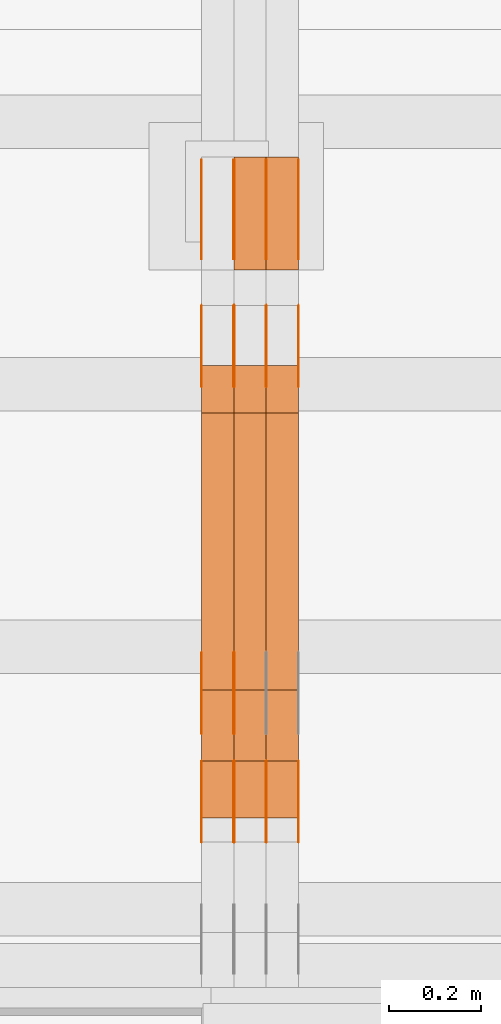
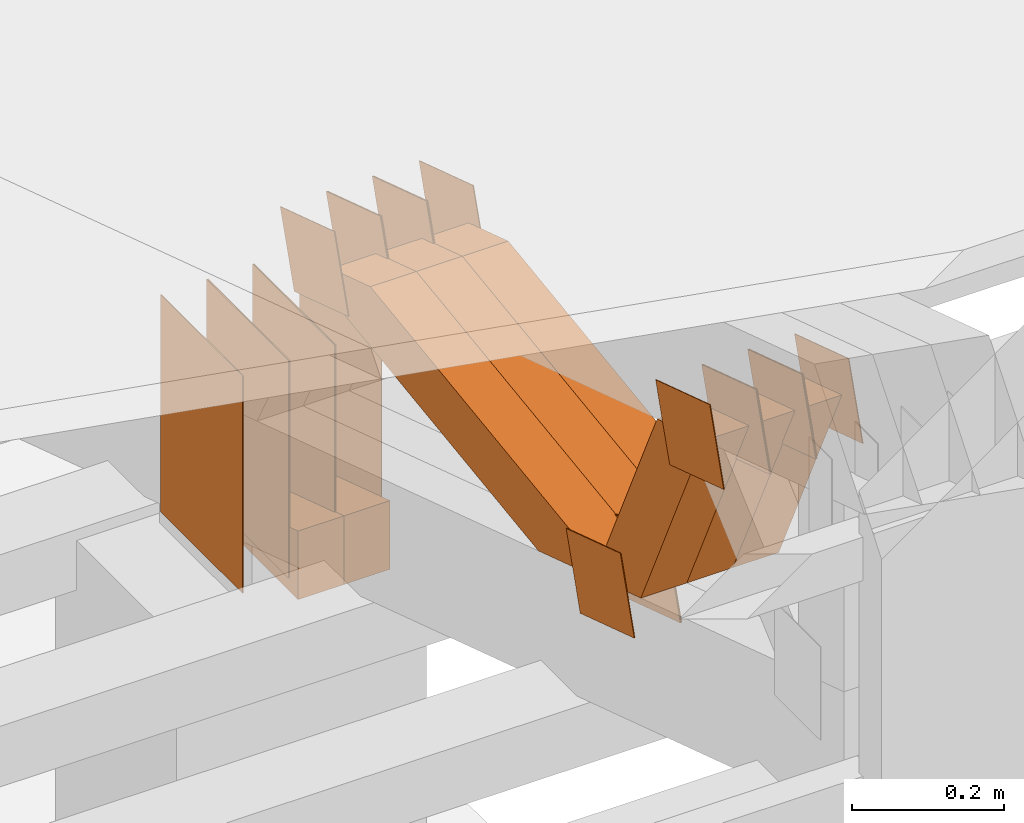
# One storey, part 303 of 385: 29 proxies.
"""IFC2X3 building model written with IfcOpenShell, lengths in millimetres."""

from ifc_helpers import new_model, entity, si_unit, converted_unit, derived_unit, direction, frame, origin, origin_2d_with_axis, place, context, subcontext, project, spatial, polyline, rectangle, outline, extrude, source, transform, mapped, material, type_object, type_shapes, element, save


model = new_model("IFC2X3")

# Units and contexts
model_context = context("Model", 3, precision=0.01, world=origin(), true_north=direction((6.12303176911189e-17, 1.0)))
body_context = subcontext(model_context, "Body", "Model", "MODEL_VIEW")
ifc_project = project(units=[si_unit("LENGTHUNIT", "METRE", prefix="MILLI"), si_unit("AREAUNIT", "SQUARE_METRE"), si_unit("VOLUMEUNIT", "CUBIC_METRE"), converted_unit("PLANEANGLEUNIT", "DEGREE", entity("IfcRatioMeasure", 0.0174532925199433), si_unit("PLANEANGLEUNIT", "RADIAN"), dimensions=[0, 0, 0, 0, 0, 0, 0]), si_unit("MASSUNIT", "GRAM", prefix="KILO"), derived_unit("MASSDENSITYUNIT", [(si_unit("MASSUNIT", "GRAM", prefix="KILO"), 1), (si_unit("LENGTHUNIT", "METRE"), -3)]), si_unit("TIMEUNIT", "SECOND"), si_unit("FREQUENCYUNIT", "HERTZ"), si_unit("THERMODYNAMICTEMPERATUREUNIT", "DEGREE_CELSIUS"), derived_unit("THERMALTRANSMITTANCEUNIT", [(si_unit("MASSUNIT", "GRAM", prefix="KILO"), 1), (si_unit("THERMODYNAMICTEMPERATUREUNIT", "KELVIN"), -1), (si_unit("TIMEUNIT", "SECOND"), -3)]), derived_unit("VOLUMETRICFLOWRATEUNIT", [(si_unit("LENGTHUNIT", "METRE"), 3), (si_unit("TIMEUNIT", "SECOND"), -1)]), si_unit("ELECTRICCURRENTUNIT", "AMPERE"), si_unit("ELECTRICVOLTAGEUNIT", "VOLT"), si_unit("POWERUNIT", "WATT"), si_unit("FORCEUNIT", "NEWTON", prefix="KILO"), si_unit("ILLUMINANCEUNIT", "LUX"), si_unit("LUMINOUSFLUXUNIT", "LUMEN"), si_unit("LUMINOUSINTENSITYUNIT", "CANDELA"), derived_unit("USERDEFINED", [(si_unit("MASSUNIT", "GRAM", prefix="KILO"), -1), (si_unit("LENGTHUNIT", "METRE"), -2), (si_unit("TIMEUNIT", "SECOND"), 3), (si_unit("LUMINOUSFLUXUNIT", "LUMEN"), 1)]), derived_unit("LINEARVELOCITYUNIT", [(si_unit("LENGTHUNIT", "METRE"), 1), (si_unit("TIMEUNIT", "SECOND"), -1)]), si_unit("PRESSUREUNIT", "PASCAL"), derived_unit("USERDEFINED", [(si_unit("LENGTHUNIT", "METRE"), -2), (si_unit("MASSUNIT", "GRAM", prefix="KILO"), 1), (si_unit("TIMEUNIT", "SECOND"), -2)])], contexts=[model_context])

# Site, building, storey
site_placement = place(None, origin())
site = spatial("IfcSite", under=ifc_project, at=site_placement, CompositionType="ELEMENT")
building_placement = place(site_placement, origin())
building = spatial("IfcBuilding", under=site, at=building_placement, CompositionType="ELEMENT")
storey_placement = place(building_placement, origin())
storey = spatial("IfcBuildingStorey", under=building, at=storey_placement, Name="Default", CompositionType="ELEMENT", Elevation=0.0)

# Proxies
ifc_material_1 = material(Name="IfcSurfaceStyle #549185")
building_element_proxy_type_1 = type_object("IfcBuildingElementProxyType", PredefinedType="NOTDEFINED", material=ifc_material_1)
shared_shape_1 = source(origin(), body_context, "Body", "SweptSolid", [
    extrude(outline(polyline([(-74.9998605591118, -59.9999264677601), (74.9998754286171, -59.9999264677601), (74.9998605591118, 59.9999264677602), (-74.9998754286171, 59.9999264677602), (-74.9998605591118, -59.9999264677601)])), frame((74.9998754286171, 60.0000503992849, 0.0), z_axis=(0.0, 0.0, 1.0), x_axis=(-1.0, 0.0, 0.0)), (0.0, 0.0, 1.0), 1.29999999999999),
])
type_shapes(building_element_proxy_type_1, [shared_shape_1])
proxy_1_placement = place(building_placement, frame((45245.0, 16352.8320303235, 3323.23212676408), z_axis=(-1.0, 0.0, 0.0), x_axis=(0.0, -0.951056516295124, 0.309016994375039)))
element("IfcBuildingElementProxy", 1, at=proxy_1_placement, inside=storey, type_object=building_element_proxy_type_1, material=ifc_material_1, context=body_context, shape_type="MappedRepresentation", body=[
    mapped(shared_shape_1, transform((0.0, 0.0, 0.0), scale=1.0)),
])
ifc_material_2 = material(Name="IfcSurfaceStyle #549128")
building_element_proxy_type_2 = type_object("IfcBuildingElementProxyType", PredefinedType="NOTDEFINED", material=ifc_material_2)
shared_shape_2 = source(origin(), body_context, "Body", "SweptSolid", [
    extrude(outline(polyline([(-74.9998605591118, -59.9999264677601), (74.9998754286171, -59.9999264677601), (74.9998605591118, 59.9999264677602), (-74.9998754286171, 59.9999264677602), (-74.9998605591118, -59.9999264677601)])), frame((74.9998754286171, 60.0000503992849, 0.0), z_axis=(0.0, 0.0, 1.0), x_axis=(-1.0, 0.0, 0.0)), (0.0, 0.0, 1.0), 1.29999999999999),
])
type_shapes(building_element_proxy_type_2, [shared_shape_2])
proxy_2_placement = place(building_placement, frame((45246.3, 16352.8320303235, 3323.23212676408), z_axis=(-1.0, 0.0, 0.0), x_axis=(0.0, -0.951056516295124, 0.309016994375039)))
element("IfcBuildingElementProxy", 2, at=proxy_2_placement, inside=storey, type_object=building_element_proxy_type_2, material=ifc_material_2, context=body_context, shape_type="MappedRepresentation", body=[
    mapped(shared_shape_2, transform((0.0, 0.0, 0.0), scale=1.0)),
])
ifc_material_3 = material(Name="IfcSurfaceStyle #549071")
building_element_proxy_type_3 = type_object("IfcBuildingElementProxyType", PredefinedType="NOTDEFINED", material=ifc_material_3)
shared_shape_3 = source(origin(), body_context, "Body", "SweptSolid", [
    extrude(outline(polyline([(-74.9998605591118, -59.9999264677601), (74.9998754286171, -59.9999264677601), (74.9998605591118, 59.9999264677602), (-74.9998754286171, 59.9999264677602), (-74.9998605591118, -59.9999264677601)])), frame((74.9998754286171, 60.0000503992849, 0.0), z_axis=(0.0, 0.0, 1.0), x_axis=(-1.0, 0.0, 0.0)), (0.0, 0.0, 1.0), 1.29999999999999),
])
type_shapes(building_element_proxy_type_3, [shared_shape_3])
proxy_3_placement = place(building_placement, frame((45175.0, 16352.8320303235, 3323.23212676408), z_axis=(-1.0, 0.0, 0.0), x_axis=(0.0, -0.951056516295124, 0.309016994375039)))
element("IfcBuildingElementProxy", 3, at=proxy_3_placement, inside=storey, type_object=building_element_proxy_type_3, material=ifc_material_3, context=body_context, shape_type="MappedRepresentation", body=[
    mapped(shared_shape_3, transform((0.0, 0.0, 0.0), scale=1.0)),
])
ifc_material_4 = material(Name="IfcSurfaceStyle #546962")
building_element_proxy_type_4 = type_object("IfcBuildingElementProxyType", PredefinedType="NOTDEFINED", material=ifc_material_4)
shared_shape_4 = source(origin(), body_context, "Body", "SweptSolid", [
    extrude(rectangle(XDim=350.0, YDim=215.999999999984, at=origin_2d_with_axis()), frame((175.0, 108.0, 0.0), z_axis=(0.0, 0.0, 1.0), x_axis=(-1.0, 0.0, 0.0)), (0.0, 0.0, 1.0), 1.29999999999999),
])
type_shapes(building_element_proxy_type_4, [shared_shape_4])
proxy_4_placement = place(building_placement, frame((45386.3, 17459.2939453125, 3165.36425781251), z_axis=(-1.0, 0.0, 0.0), x_axis=(0.0, 0.0, -1.0)))
element("IfcBuildingElementProxy", 4, at=proxy_4_placement, inside=storey, type_object=building_element_proxy_type_4, material=ifc_material_4, context=body_context, shape_type="MappedRepresentation", body=[
    mapped(shared_shape_4, transform((0.0, 0.0, 0.0), scale=1.0)),
])
ifc_material_5 = material(Name="IfcSurfaceStyle #546905")
building_element_proxy_type_5 = type_object("IfcBuildingElementProxyType", PredefinedType="NOTDEFINED", material=ifc_material_5)
shared_shape_5 = source(origin(), body_context, "Body", "SweptSolid", [
    extrude(rectangle(XDim=350.0, YDim=215.999999999984, at=origin_2d_with_axis()), frame((175.0, 108.0, 0.0), z_axis=(0.0, 0.0, 1.0), x_axis=(-1.0, 0.0, 0.0)), (0.0, 0.0, 1.0), 1.29999999999999),
])
type_shapes(building_element_proxy_type_5, [shared_shape_5])
proxy_5_placement = place(building_placement, frame((45315.0, 17459.2939453125, 3165.36425781251), z_axis=(-1.0, 0.0, 0.0), x_axis=(0.0, 0.0, -1.0)))
element("IfcBuildingElementProxy", 5, at=proxy_5_placement, inside=storey, type_object=building_element_proxy_type_5, material=ifc_material_5, context=body_context, shape_type="MappedRepresentation", body=[
    mapped(shared_shape_5, transform((0.0, 0.0, 0.0), scale=1.0)),
])
ifc_material_6 = material(Name="IfcSurfaceStyle #546848")
building_element_proxy_type_6 = type_object("IfcBuildingElementProxyType", PredefinedType="NOTDEFINED", material=ifc_material_6)
shared_shape_6 = source(origin(), body_context, "Body", "SweptSolid", [
    extrude(rectangle(XDim=350.0, YDim=215.999999999984, at=origin_2d_with_axis()), frame((175.0, 108.0, 0.0), z_axis=(0.0, 0.0, 1.0), x_axis=(-1.0, 0.0, 0.0)), (0.0, 0.0, 1.0), 1.29999999999999),
])
type_shapes(building_element_proxy_type_6, [shared_shape_6])
proxy_6_placement = place(building_placement, frame((45316.3, 17459.2939453125, 3165.36425781251), z_axis=(-1.0, 0.0, 0.0), x_axis=(0.0, 0.0, -1.0)))
element("IfcBuildingElementProxy", 6, at=proxy_6_placement, inside=storey, type_object=building_element_proxy_type_6, material=ifc_material_6, context=body_context, shape_type="MappedRepresentation", body=[
    mapped(shared_shape_6, transform((0.0, 0.0, 0.0), scale=1.0)),
])
ifc_material_7 = material(Name="IfcSurfaceStyle #546791")
building_element_proxy_type_7 = type_object("IfcBuildingElementProxyType", PredefinedType="NOTDEFINED", material=ifc_material_7)
shared_shape_7 = source(origin(), body_context, "Body", "SweptSolid", [
    extrude(rectangle(XDim=350.0, YDim=215.999999999984, at=origin_2d_with_axis()), frame((175.0, 108.0, 0.0), z_axis=(0.0, 0.0, 1.0), x_axis=(-1.0, 0.0, 0.0)), (0.0, 0.0, 1.0), 1.29999999999998),
])
type_shapes(building_element_proxy_type_7, [shared_shape_7])
proxy_7_placement = place(building_placement, frame((45245.0, 17459.2939453125, 3165.36425781251), z_axis=(-1.0, 0.0, 0.0), x_axis=(0.0, 0.0, -1.0)))
element("IfcBuildingElementProxy", 7, at=proxy_7_placement, inside=storey, type_object=building_element_proxy_type_7, material=ifc_material_7, context=body_context, shape_type="MappedRepresentation", body=[
    mapped(shared_shape_7, transform((0.0, 0.0, 0.0), scale=1.0)),
])
ifc_material_8 = material(Name="IfcSurfaceStyle #546734")
building_element_proxy_type_8 = type_object("IfcBuildingElementProxyType", PredefinedType="NOTDEFINED", material=ifc_material_8)
shared_shape_8 = source(origin(), body_context, "Body", "SweptSolid", [
    extrude(rectangle(XDim=350.0, YDim=215.999999999984, at=origin_2d_with_axis()), frame((175.0, 108.0, 0.0), z_axis=(0.0, 0.0, 1.0), x_axis=(-1.0, 0.0, 0.0)), (0.0, 0.0, 1.0), 1.29999999999998),
])
type_shapes(building_element_proxy_type_8, [shared_shape_8])
proxy_8_placement = place(building_placement, frame((45246.3, 17459.2939453125, 3165.36425781251), z_axis=(-1.0, 0.0, 0.0), x_axis=(0.0, 0.0, -1.0)))
element("IfcBuildingElementProxy", 8, at=proxy_8_placement, inside=storey, type_object=building_element_proxy_type_8, material=ifc_material_8, context=body_context, shape_type="MappedRepresentation", body=[
    mapped(shared_shape_8, transform((0.0, 0.0, 0.0), scale=1.0)),
])
ifc_material_9 = material(Name="IfcSurfaceStyle #546677")
building_element_proxy_type_9 = type_object("IfcBuildingElementProxyType", PredefinedType="NOTDEFINED", material=ifc_material_9)
shared_shape_9 = source(origin(), body_context, "Body", "SweptSolid", [
    extrude(rectangle(XDim=350.0, YDim=215.999999999984, at=origin_2d_with_axis()), frame((175.0, 108.0, 0.0), z_axis=(0.0, 0.0, 1.0), x_axis=(-1.0, 0.0, 0.0)), (0.0, 0.0, 1.0), 1.29999999999998),
])
type_shapes(building_element_proxy_type_9, [shared_shape_9])
proxy_9_placement = place(building_placement, frame((45175.0, 17459.2939453125, 3165.36425781251), z_axis=(-1.0, 0.0, 0.0), x_axis=(0.0, 0.0, -1.0)))
element("IfcBuildingElementProxy", 9, at=proxy_9_placement, inside=storey, type_object=building_element_proxy_type_9, material=ifc_material_9, context=body_context, shape_type="MappedRepresentation", body=[
    mapped(shared_shape_9, transform((0.0, 0.0, 0.0), scale=1.0)),
])
ifc_material_10 = material(Name="IfcSurfaceStyle #544910")
building_element_proxy_type_10 = type_object("IfcBuildingElementProxyType", PredefinedType="NOTDEFINED", material=ifc_material_10)
shared_shape_10 = source(origin(), body_context, "Body", "SweptSolid", [
    extrude(outline(polyline([(-75.0003249421702, -60.0000773549573), (75.0003398116874, -60.0000773549573), (75.0003249421711, 60.0000773549573), (-75.0003398116883, 60.0000773549573), (-75.0003249421702, -60.0000773549573)])), frame((75.0003398116874, 60.0000773549573, 0.0), z_axis=(0.0, 0.0, 1.0), x_axis=(-1.0, 0.0, 0.0)), (0.0, 0.0, 1.0), 1.3),
])
type_shapes(building_element_proxy_type_10, [shared_shape_10])
proxy_10_placement = place(building_placement, frame((45386.3, 16117.0849050545, 3705.49074668796), z_axis=(-1.0, 0.0, 0.0), x_axis=(0.0, -0.951056516295154, 0.309016994374948)))
element("IfcBuildingElementProxy", 10, at=proxy_10_placement, inside=storey, type_object=building_element_proxy_type_10, material=ifc_material_10, context=body_context, shape_type="MappedRepresentation", body=[
    mapped(shared_shape_10, transform((0.0, 0.0, 0.0), scale=1.0)),
])
ifc_material_11 = material(Name="IfcSurfaceStyle #544853")
building_element_proxy_type_11 = type_object("IfcBuildingElementProxyType", PredefinedType="NOTDEFINED", material=ifc_material_11)
shared_shape_11 = source(origin(), body_context, "Body", "SweptSolid", [
    extrude(outline(polyline([(-75.0003249421702, -60.0000773549573), (75.0003398116874, -60.0000773549573), (75.0003249421711, 60.0000773549573), (-75.0003398116883, 60.0000773549573), (-75.0003249421702, -60.0000773549573)])), frame((75.0003398116874, 60.0000773549573, 0.0), z_axis=(0.0, 0.0, 1.0), x_axis=(-1.0, 0.0, 0.0)), (0.0, 0.0, 1.0), 1.3),
])
type_shapes(building_element_proxy_type_11, [shared_shape_11])
proxy_11_placement = place(building_placement, frame((45315.0, 16117.0849050545, 3705.49074668796), z_axis=(-1.0, 0.0, 0.0), x_axis=(0.0, -0.951056516295154, 0.309016994374948)))
element("IfcBuildingElementProxy", 11, at=proxy_11_placement, inside=storey, type_object=building_element_proxy_type_11, material=ifc_material_11, context=body_context, shape_type="MappedRepresentation", body=[
    mapped(shared_shape_11, transform((0.0, 0.0, 0.0), scale=1.0)),
])
ifc_material_12 = material(Name="IfcSurfaceStyle #544796")
building_element_proxy_type_12 = type_object("IfcBuildingElementProxyType", PredefinedType="NOTDEFINED", material=ifc_material_12)
shared_shape_12 = source(origin(), body_context, "Body", "SweptSolid", [
    extrude(outline(polyline([(-75.0003249421702, -60.0000773549573), (75.0003398116874, -60.0000773549573), (75.0003249421711, 60.0000773549573), (-75.0003398116883, 60.0000773549573), (-75.0003249421702, -60.0000773549573)])), frame((75.0003398116874, 60.0000773549573, 0.0), z_axis=(0.0, 0.0, 1.0), x_axis=(-1.0, 0.0, 0.0)), (0.0, 0.0, 1.0), 1.3),
])
type_shapes(building_element_proxy_type_12, [shared_shape_12])
proxy_12_placement = place(building_placement, frame((45316.3, 16117.0849050545, 3705.49074668796), z_axis=(-1.0, 0.0, 0.0), x_axis=(0.0, -0.951056516295154, 0.309016994374948)))
element("IfcBuildingElementProxy", 12, at=proxy_12_placement, inside=storey, type_object=building_element_proxy_type_12, material=ifc_material_12, context=body_context, shape_type="MappedRepresentation", body=[
    mapped(shared_shape_12, transform((0.0, 0.0, 0.0), scale=1.0)),
])
ifc_material_13 = material(Name="IfcSurfaceStyle #544739")
building_element_proxy_type_13 = type_object("IfcBuildingElementProxyType", PredefinedType="NOTDEFINED", material=ifc_material_13)
shared_shape_13 = source(origin(), body_context, "Body", "SweptSolid", [
    extrude(outline(polyline([(-75.0003249421702, -60.0000773549573), (75.0003398116874, -60.0000773549573), (75.0003249421711, 60.0000773549573), (-75.0003398116883, 60.0000773549573), (-75.0003249421702, -60.0000773549573)])), frame((75.0003398116874, 60.0000773549573, 0.0), z_axis=(0.0, 0.0, 1.0), x_axis=(-1.0, 0.0, 0.0)), (0.0, 0.0, 1.0), 1.29999999999999),
])
type_shapes(building_element_proxy_type_13, [shared_shape_13])
proxy_13_placement = place(building_placement, frame((45245.0, 16117.0849050545, 3705.49074668796), z_axis=(-1.0, 0.0, 0.0), x_axis=(0.0, -0.951056516295154, 0.309016994374948)))
element("IfcBuildingElementProxy", 13, at=proxy_13_placement, inside=storey, type_object=building_element_proxy_type_13, material=ifc_material_13, context=body_context, shape_type="MappedRepresentation", body=[
    mapped(shared_shape_13, transform((0.0, 0.0, 0.0), scale=1.0)),
])
ifc_material_14 = material(Name="IfcSurfaceStyle #544682")
building_element_proxy_type_14 = type_object("IfcBuildingElementProxyType", PredefinedType="NOTDEFINED", material=ifc_material_14)
shared_shape_14 = source(origin(), body_context, "Body", "SweptSolid", [
    extrude(outline(polyline([(-75.0003249421702, -60.0000773549573), (75.0003398116874, -60.0000773549573), (75.0003249421711, 60.0000773549573), (-75.0003398116883, 60.0000773549573), (-75.0003249421702, -60.0000773549573)])), frame((75.0003398116874, 60.0000773549573, 0.0), z_axis=(0.0, 0.0, 1.0), x_axis=(-1.0, 0.0, 0.0)), (0.0, 0.0, 1.0), 1.29999999999999),
])
type_shapes(building_element_proxy_type_14, [shared_shape_14])
proxy_14_placement = place(building_placement, frame((45246.3, 16117.0849050545, 3705.49074668796), z_axis=(-1.0, 0.0, 0.0), x_axis=(0.0, -0.951056516295154, 0.309016994374948)))
element("IfcBuildingElementProxy", 14, at=proxy_14_placement, inside=storey, type_object=building_element_proxy_type_14, material=ifc_material_14, context=body_context, shape_type="MappedRepresentation", body=[
    mapped(shared_shape_14, transform((0.0, 0.0, 0.0), scale=1.0)),
])
ifc_material_15 = material(Name="IfcSurfaceStyle #544625")
building_element_proxy_type_15 = type_object("IfcBuildingElementProxyType", PredefinedType="NOTDEFINED", material=ifc_material_15)
shared_shape_15 = source(origin(), body_context, "Body", "SweptSolid", [
    extrude(outline(polyline([(-75.0003249421702, -60.0000773549573), (75.0003398116874, -60.0000773549573), (75.0003249421711, 60.0000773549573), (-75.0003398116883, 60.0000773549573), (-75.0003249421702, -60.0000773549573)])), frame((75.0003398116874, 60.0000773549573, 0.0), z_axis=(0.0, 0.0, 1.0), x_axis=(-1.0, 0.0, 0.0)), (0.0, 0.0, 1.0), 1.29999999999999),
])
type_shapes(building_element_proxy_type_15, [shared_shape_15])
proxy_15_placement = place(building_placement, frame((45175.0, 16117.0849050545, 3705.49074668796), z_axis=(-1.0, 0.0, 0.0), x_axis=(0.0, -0.951056516295154, 0.309016994374948)))
element("IfcBuildingElementProxy", 15, at=proxy_15_placement, inside=storey, type_object=building_element_proxy_type_15, material=ifc_material_15, context=body_context, shape_type="MappedRepresentation", body=[
    mapped(shared_shape_15, transform((0.0, 0.0, 0.0), scale=1.0)),
])
ifc_material_16 = material(Name="IfcSurfaceStyle #543542")
building_element_proxy_type_16 = type_object("IfcBuildingElementProxyType", PredefinedType="NOTDEFINED", material=ifc_material_16)
shared_shape_16 = source(origin(), body_context, "Body", "SweptSolid", [
    extrude(outline(polyline([(-74.9998605591058, -59.9999264677524), (74.999875428623, -59.9999264677524), (74.9998605591068, 59.9999264677524), (-74.9998754286239, 59.9999264677524), (-74.9998605591058, -59.9999264677524)])), frame((75.0002460484325, 60.0000016373508, 0.0), z_axis=(0.0, 0.0, 1.0), x_axis=(-1.0, 0.0, 0.0)), (0.0, 0.0, 1.0), 1.3),
])
type_shapes(building_element_proxy_type_16, [shared_shape_16])
proxy_16_placement = place(building_placement, frame((45386.3, 17107.0599369346, 3383.82825001787), z_axis=(-1.0, 0.0, 0.0), x_axis=(0.0, -0.951056516295154, 0.309016994374948)))
element("IfcBuildingElementProxy", 16, at=proxy_16_placement, inside=storey, type_object=building_element_proxy_type_16, material=ifc_material_16, context=body_context, shape_type="MappedRepresentation", body=[
    mapped(shared_shape_16, transform((0.0, 0.0, 0.0), scale=1.0)),
])
ifc_material_17 = material(Name="IfcSurfaceStyle #543485")
building_element_proxy_type_17 = type_object("IfcBuildingElementProxyType", PredefinedType="NOTDEFINED", material=ifc_material_17)
shared_shape_17 = source(origin(), body_context, "Body", "SweptSolid", [
    extrude(outline(polyline([(-74.9998605591058, -59.9999264677524), (74.999875428623, -59.9999264677524), (74.9998605591068, 59.9999264677524), (-74.9998754286239, 59.9999264677524), (-74.9998605591058, -59.9999264677524)])), frame((75.0002460484325, 60.0000016373508, 0.0), z_axis=(0.0, 0.0, 1.0), x_axis=(-1.0, 0.0, 0.0)), (0.0, 0.0, 1.0), 1.3),
])
type_shapes(building_element_proxy_type_17, [shared_shape_17])
proxy_17_placement = place(building_placement, frame((45315.0, 17107.0599369346, 3383.82825001787), z_axis=(-1.0, 0.0, 0.0), x_axis=(0.0, -0.951056516295154, 0.309016994374948)))
element("IfcBuildingElementProxy", 17, at=proxy_17_placement, inside=storey, type_object=building_element_proxy_type_17, material=ifc_material_17, context=body_context, shape_type="MappedRepresentation", body=[
    mapped(shared_shape_17, transform((0.0, 0.0, 0.0), scale=1.0)),
])
ifc_material_18 = material(Name="IfcSurfaceStyle #543428")
building_element_proxy_type_18 = type_object("IfcBuildingElementProxyType", PredefinedType="NOTDEFINED", material=ifc_material_18)
shared_shape_18 = source(origin(), body_context, "Body", "SweptSolid", [
    extrude(outline(polyline([(-74.9998605591058, -59.9999264677524), (74.999875428623, -59.9999264677524), (74.9998605591068, 59.9999264677524), (-74.9998754286239, 59.9999264677524), (-74.9998605591058, -59.9999264677524)])), frame((75.0002460484325, 60.0000016373508, 0.0), z_axis=(0.0, 0.0, 1.0), x_axis=(-1.0, 0.0, 0.0)), (0.0, 0.0, 1.0), 1.3),
])
type_shapes(building_element_proxy_type_18, [shared_shape_18])
proxy_18_placement = place(building_placement, frame((45316.3, 17107.0599369346, 3383.82825001787), z_axis=(-1.0, 0.0, 0.0), x_axis=(0.0, -0.951056516295154, 0.309016994374948)))
element("IfcBuildingElementProxy", 18, at=proxy_18_placement, inside=storey, type_object=building_element_proxy_type_18, material=ifc_material_18, context=body_context, shape_type="MappedRepresentation", body=[
    mapped(shared_shape_18, transform((0.0, 0.0, 0.0), scale=1.0)),
])
ifc_material_19 = material(Name="IfcSurfaceStyle #543371")
building_element_proxy_type_19 = type_object("IfcBuildingElementProxyType", PredefinedType="NOTDEFINED", material=ifc_material_19)
shared_shape_19 = source(origin(), body_context, "Body", "SweptSolid", [
    extrude(outline(polyline([(-74.9998605591058, -59.9999264677524), (74.999875428623, -59.9999264677524), (74.9998605591068, 59.9999264677524), (-74.9998754286239, 59.9999264677524), (-74.9998605591058, -59.9999264677524)])), frame((75.0002460484325, 60.0000016373508, 0.0), z_axis=(0.0, 0.0, 1.0), x_axis=(-1.0, 0.0, 0.0)), (0.0, 0.0, 1.0), 1.29999999999999),
])
type_shapes(building_element_proxy_type_19, [shared_shape_19])
proxy_19_placement = place(building_placement, frame((45245.0, 17107.0599369346, 3383.82825001787), z_axis=(-1.0, 0.0, 0.0), x_axis=(0.0, -0.951056516295154, 0.309016994374948)))
element("IfcBuildingElementProxy", 19, at=proxy_19_placement, inside=storey, type_object=building_element_proxy_type_19, material=ifc_material_19, context=body_context, shape_type="MappedRepresentation", body=[
    mapped(shared_shape_19, transform((0.0, 0.0, 0.0), scale=1.0)),
])
ifc_material_20 = material(Name="IfcSurfaceStyle #543314")
building_element_proxy_type_20 = type_object("IfcBuildingElementProxyType", PredefinedType="NOTDEFINED", material=ifc_material_20)
shared_shape_20 = source(origin(), body_context, "Body", "SweptSolid", [
    extrude(outline(polyline([(-74.9998605591058, -59.9999264677524), (74.999875428623, -59.9999264677524), (74.9998605591068, 59.9999264677524), (-74.9998754286239, 59.9999264677524), (-74.9998605591058, -59.9999264677524)])), frame((75.0002460484325, 60.0000016373508, 0.0), z_axis=(0.0, 0.0, 1.0), x_axis=(-1.0, 0.0, 0.0)), (0.0, 0.0, 1.0), 1.29999999999999),
])
type_shapes(building_element_proxy_type_20, [shared_shape_20])
proxy_20_placement = place(building_placement, frame((45246.3, 17107.0599369346, 3383.82825001787), z_axis=(-1.0, 0.0, 0.0), x_axis=(0.0, -0.951056516295154, 0.309016994374948)))
element("IfcBuildingElementProxy", 20, at=proxy_20_placement, inside=storey, type_object=building_element_proxy_type_20, material=ifc_material_20, context=body_context, shape_type="MappedRepresentation", body=[
    mapped(shared_shape_20, transform((0.0, 0.0, 0.0), scale=1.0)),
])
ifc_material_21 = material(Name="IfcSurfaceStyle #543257")
building_element_proxy_type_21 = type_object("IfcBuildingElementProxyType", PredefinedType="NOTDEFINED", material=ifc_material_21)
shared_shape_21 = source(origin(), body_context, "Body", "SweptSolid", [
    extrude(outline(polyline([(-74.9998605591058, -59.9999264677524), (74.999875428623, -59.9999264677524), (74.9998605591068, 59.9999264677524), (-74.9998754286239, 59.9999264677524), (-74.9998605591058, -59.9999264677524)])), frame((75.0002460484325, 60.0000016373508, 0.0), z_axis=(0.0, 0.0, 1.0), x_axis=(-1.0, 0.0, 0.0)), (0.0, 0.0, 1.0), 1.29999999999999),
])
type_shapes(building_element_proxy_type_21, [shared_shape_21])
proxy_21_placement = place(building_placement, frame((45175.0, 17107.0599369346, 3383.82825001787), z_axis=(-1.0, 0.0, 0.0), x_axis=(0.0, -0.951056516295154, 0.309016994374948)))
element("IfcBuildingElementProxy", 21, at=proxy_21_placement, inside=storey, type_object=building_element_proxy_type_21, material=ifc_material_21, context=body_context, shape_type="MappedRepresentation", body=[
    mapped(shared_shape_21, transform((0.0, 0.0, 0.0), scale=1.0)),
])
ifc_material_22 = material(Name="IfcSurfaceStyle #535253")
building_element_proxy_type_22 = type_object("IfcBuildingElementProxyType", Name="T1-E1 535251", PredefinedType="NOTDEFINED", material=ifc_material_22)
shared_shape_22 = source(origin(), body_context, "Body", "SweptSolid", [
    extrude(outline(polyline([(4.4675903320374, -122.500000000001), (35.3350219726624, -122.500000000001), (35.3350219726501, 122.500000000001), (-75.1376342773499, 122.500000000001), (4.4675903320374, -122.500000000001)])), frame((35.3350219726624, 122.50000005215, 0.0), z_axis=(0.0, 0.0, 1.0), x_axis=(-1.0, 0.0, 0.0)), (0.0, 0.0, 1.0), 70.0),
])
type_shapes(building_element_proxy_type_22, [shared_shape_22])
proxy_22_placement = place(building_placement, frame((45385.0, 17220.0, 2794.30932617186), z_axis=(-1.0, 0.0, 0.0), x_axis=(0.0, 0.0, 1.0)))
element("IfcBuildingElementProxy", 22, at=proxy_22_placement, inside=storey, type_object=building_element_proxy_type_22, material=ifc_material_22, Name="T1-E1", context=body_context, shape_type="MappedRepresentation", body=[
    mapped(shared_shape_22, transform((0.0, 0.0, 0.0), scale=1.0)),
])
ifc_material_23 = material(Name="IfcSurfaceStyle #535196")
building_element_proxy_type_23 = type_object("IfcBuildingElementProxyType", Name="T1-E1 535194", PredefinedType="NOTDEFINED", material=ifc_material_23)
shared_shape_23 = source(origin(), body_context, "Body", "SweptSolid", [
    extrude(outline(polyline([(4.4675903320374, -122.500000000001), (35.3350219726624, -122.500000000001), (35.3350219726501, 122.500000000001), (-75.1376342773499, 122.500000000001), (4.4675903320374, -122.500000000001)])), frame((35.3350219726624, 122.50000005215, 0.0), z_axis=(0.0, 0.0, 1.0), x_axis=(-1.0, 0.0, 0.0)), (0.0, 0.0, 1.0), 70.0),
])
type_shapes(building_element_proxy_type_23, [shared_shape_23])
proxy_23_placement = place(building_placement, frame((45315.0, 17220.0, 2794.30932617186), z_axis=(-1.0, 0.0, 0.0), x_axis=(0.0, 0.0, 1.0)))
element("IfcBuildingElementProxy", 23, at=proxy_23_placement, inside=storey, type_object=building_element_proxy_type_23, material=ifc_material_23, Name="T1-E1", context=body_context, shape_type="MappedRepresentation", body=[
    mapped(shared_shape_23, transform((0.0, 0.0, 0.0), scale=1.0)),
])
ifc_material_24 = material(Name="IfcSurfaceStyle #534290")
building_element_proxy_type_24 = type_object("IfcBuildingElementProxyType", Name="T1-W44 534288", PredefinedType="NOTDEFINED", material=ifc_material_24)
shared_shape_24 = source(origin(), body_context, "Body", "SweptSolid", [
    extrude(outline(polyline([(-184.551057772692, -47.4997984945814), (177.527112951531, -47.4997984945814), (162.630077773546, -0.000452497529500495), (118.068221667048, 47.5000247433462), (-273.674354619433, 47.5000247433462), (-184.551057772692, -47.4997984945814)])), frame((177.527112951531, 47.5002721629815, 0.0), z_axis=(0.0, 0.0, 1.0), x_axis=(-1.0, 0.0, 0.0)), (0.0, 0.0, 1.0), 70.0),
])
type_shapes(building_element_proxy_type_24, [shared_shape_24])
proxy_24_placement = place(building_placement, frame((45385.0, 16220.4899216004, 3388.98238154171), z_axis=(-1.0, 0.0, 0.0), x_axis=(0.0, -0.425335045192995, 0.905035965766374)))
element("IfcBuildingElementProxy", 24, at=proxy_24_placement, inside=storey, type_object=building_element_proxy_type_24, material=ifc_material_24, Name="T1-W44", context=body_context, shape_type="MappedRepresentation", body=[
    mapped(shared_shape_24, transform((0.0, 0.0, 0.0), scale=1.0)),
])
ifc_material_25 = material(Name="IfcSurfaceStyle #534224")
building_element_proxy_type_25 = type_object("IfcBuildingElementProxyType", Name="T1-W44 534222", PredefinedType="NOTDEFINED", material=ifc_material_25)
shared_shape_25 = source(origin(), body_context, "Body", "SweptSolid", [
    extrude(outline(polyline([(-184.551057772692, -47.4997984945814), (177.527112951531, -47.4997984945814), (162.630077773546, -0.000452497529500495), (118.068221667048, 47.5000247433462), (-273.674354619433, 47.5000247433462), (-184.551057772692, -47.4997984945814)])), frame((177.527112951531, 47.5002721629815, 0.0), z_axis=(0.0, 0.0, 1.0), x_axis=(-1.0, 0.0, 0.0)), (0.0, 0.0, 1.0), 70.0),
])
type_shapes(building_element_proxy_type_25, [shared_shape_25])
proxy_25_placement = place(building_placement, frame((45315.0, 16220.4899216004, 3388.98238154171), z_axis=(-1.0, 0.0, 0.0), x_axis=(0.0, -0.425335045192995, 0.905035965766374)))
element("IfcBuildingElementProxy", 25, at=proxy_25_placement, inside=storey, type_object=building_element_proxy_type_25, material=ifc_material_25, Name="T1-W44", context=body_context, shape_type="MappedRepresentation", body=[
    mapped(shared_shape_25, transform((0.0, 0.0, 0.0), scale=1.0)),
])
ifc_material_26 = material(Name="IfcSurfaceStyle #534158")
building_element_proxy_type_26 = type_object("IfcBuildingElementProxyType", Name="T1-W44 534156", PredefinedType="NOTDEFINED", material=ifc_material_26)
shared_shape_26 = source(origin(), body_context, "Body", "SweptSolid", [
    extrude(outline(polyline([(-184.551057772692, -47.4997984945814), (177.527112951531, -47.4997984945814), (162.630077773546, -0.000452497529500495), (118.068221667048, 47.5000247433462), (-273.674354619433, 47.5000247433462), (-184.551057772692, -47.4997984945814)])), frame((177.527112951531, 47.5002721629815, 0.0), z_axis=(0.0, 0.0, 1.0), x_axis=(-1.0, 0.0, 0.0)), (0.0, 0.0, 1.0), 70.0),
])
type_shapes(building_element_proxy_type_26, [shared_shape_26])
proxy_26_placement = place(building_placement, frame((45245.0, 16220.4899216004, 3388.98238154171), z_axis=(-1.0, 0.0, 0.0), x_axis=(0.0, -0.425335045192995, 0.905035965766374)))
element("IfcBuildingElementProxy", 26, at=proxy_26_placement, inside=storey, type_object=building_element_proxy_type_26, material=ifc_material_26, Name="T1-W44", context=body_context, shape_type="MappedRepresentation", body=[
    mapped(shared_shape_26, transform((0.0, 0.0, 0.0), scale=1.0)),
])
ifc_material_27 = material(Name="IfcSurfaceStyle #533894")
building_element_proxy_type_27 = type_object("IfcBuildingElementProxyType", Name="T1-W8 533892", PredefinedType="NOTDEFINED", material=ifc_material_27)
shared_shape_27 = source(origin(), body_context, "Body", "SweptSolid", [
    extrude(outline(polyline([(-476.725263324644, -47.5001051695965), (180.672765845439, -47.5001051695965), (279.11020091716, -1.03605560390907e-06), (296.793624402619, 47.5001056876243), (-279.851327840575, 47.5001056876243), (-476.725263324644, -47.5001051695965)])), frame((296.793624402619, 47.5001056876243, 0.0), z_axis=(0.0, 0.0, 1.0), x_axis=(-1.0, 0.0, 0.0)), (0.0, 0.0, 1.0), 70.0),
])
type_shapes(building_element_proxy_type_27, [shared_shape_27])
proxy_27_placement = place(building_placement, frame((45385.0, 17036.40625, 3432.97192382813), z_axis=(-1.0, 0.0, 0.0), x_axis=(0.0, -0.990844046556832, -0.135011389900564)))
element("IfcBuildingElementProxy", 27, at=proxy_27_placement, inside=storey, type_object=building_element_proxy_type_27, material=ifc_material_27, Name="T1-W8", context=body_context, shape_type="MappedRepresentation", body=[
    mapped(shared_shape_27, transform((0.0, 0.0, 0.0), scale=1.0)),
])
ifc_material_28 = material(Name="IfcSurfaceStyle #533828")
building_element_proxy_type_28 = type_object("IfcBuildingElementProxyType", Name="T1-W8 533826", PredefinedType="NOTDEFINED", material=ifc_material_28)
shared_shape_28 = source(origin(), body_context, "Body", "SweptSolid", [
    extrude(outline(polyline([(-476.725263324644, -47.5001051695965), (180.672765845439, -47.5001051695965), (279.11020091716, -1.03605560390907e-06), (296.793624402619, 47.5001056876243), (-279.851327840575, 47.5001056876243), (-476.725263324644, -47.5001051695965)])), frame((296.793624402619, 47.5001056876243, 0.0), z_axis=(0.0, 0.0, 1.0), x_axis=(-1.0, 0.0, 0.0)), (0.0, 0.0, 1.0), 70.0),
])
type_shapes(building_element_proxy_type_28, [shared_shape_28])
proxy_28_placement = place(building_placement, frame((45315.0, 17036.40625, 3432.97192382813), z_axis=(-1.0, 0.0, 0.0), x_axis=(0.0, -0.990844046556832, -0.135011389900564)))
element("IfcBuildingElementProxy", 28, at=proxy_28_placement, inside=storey, type_object=building_element_proxy_type_28, material=ifc_material_28, Name="T1-W8", context=body_context, shape_type="MappedRepresentation", body=[
    mapped(shared_shape_28, transform((0.0, 0.0, 0.0), scale=1.0)),
])
ifc_material_29 = material(Name="IfcSurfaceStyle #533762")
building_element_proxy_type_29 = type_object("IfcBuildingElementProxyType", Name="T1-W8 533760", PredefinedType="NOTDEFINED", material=ifc_material_29)
shared_shape_29 = source(origin(), body_context, "Body", "SweptSolid", [
    extrude(outline(polyline([(-476.725263324644, -47.5001051695965), (180.672765845439, -47.5001051695965), (279.11020091716, -1.03605560390907e-06), (296.793624402619, 47.5001056876243), (-279.851327840575, 47.5001056876243), (-476.725263324644, -47.5001051695965)])), frame((296.793624402619, 47.5001056876243, 0.0), z_axis=(0.0, 0.0, 1.0), x_axis=(-1.0, 0.0, 0.0)), (0.0, 0.0, 1.0), 70.0),
])
type_shapes(building_element_proxy_type_29, [shared_shape_29])
proxy_29_placement = place(building_placement, frame((45245.0, 17036.40625, 3432.97192382813), z_axis=(-1.0, 0.0, 0.0), x_axis=(0.0, -0.990844046556832, -0.135011389900564)))
element("IfcBuildingElementProxy", 29, at=proxy_29_placement, inside=storey, type_object=building_element_proxy_type_29, material=ifc_material_29, Name="T1-W8", context=body_context, shape_type="MappedRepresentation", body=[
    mapped(shared_shape_29, transform((0.0, 0.0, 0.0), scale=1.0)),
])

save(model, "model.ifc")
